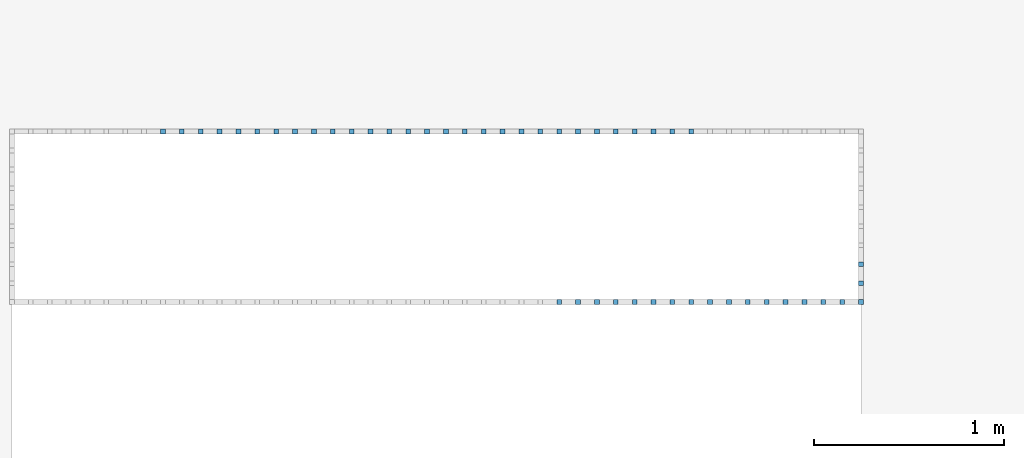
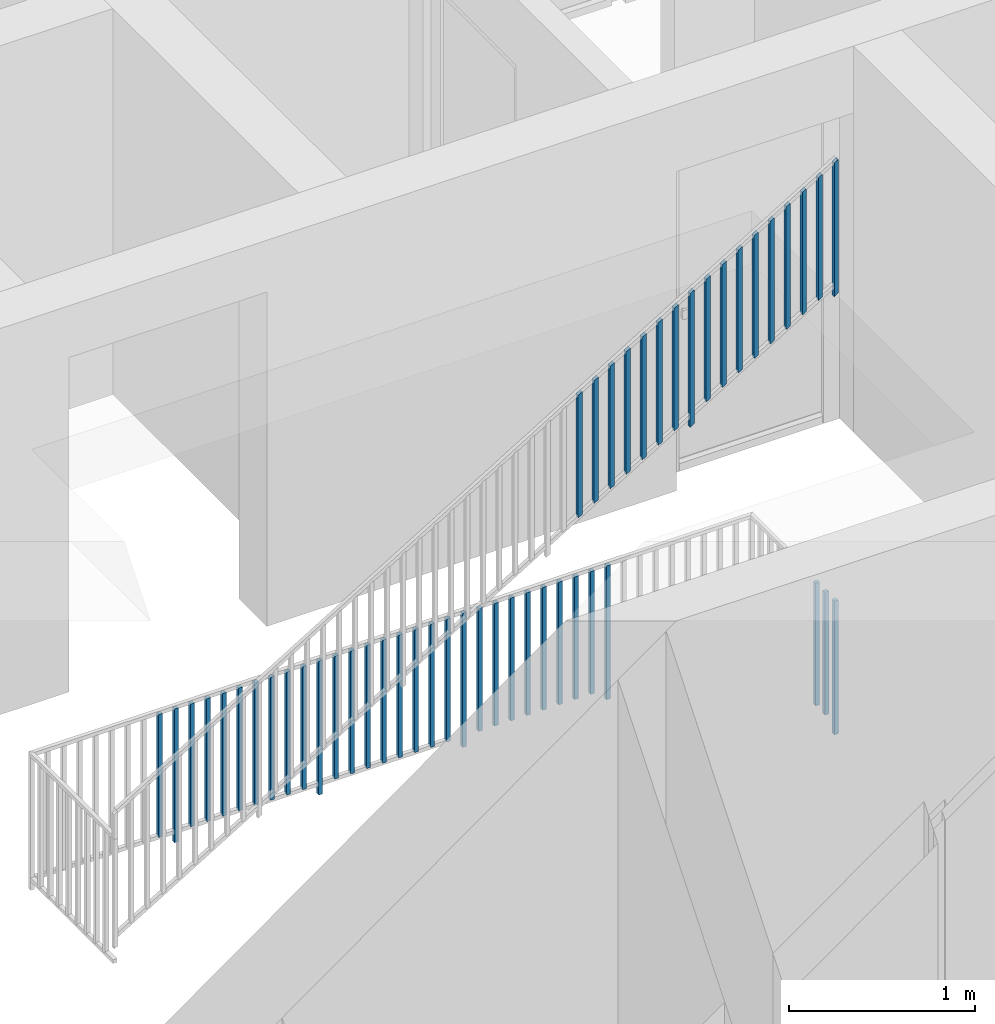
# One storey, part 40 of 54: 49 building element parts, 2 elements without a shape of their own.
"""IFC4 building model written with IfcOpenShell, lengths in metres."""

from ifc_helpers import new_model, entity, si_unit, converted_unit, derived_unit, direction, frame, origin_with_axes, place, context, subcontext, project, spatial, polygons, material, type_object, element, aggregate, save


model = new_model("IFC4")

# Units and contexts
model_context = context("Model", 3, precision=1e-05, world=origin_with_axes(), true_north=direction((0.0, 1.0)))
body_context = subcontext(model_context, "Body", "Model", "MODEL_VIEW")
ifc_project = project(units=[si_unit("LENGTHUNIT", "METRE"), si_unit("AREAUNIT", "SQUARE_METRE"), si_unit("VOLUMEUNIT", "CUBIC_METRE"), converted_unit("PLANEANGLEUNIT", "DEGREE", entity("IfcPlaneAngleMeasure", 0.0174532925199), si_unit("PLANEANGLEUNIT", "RADIAN"), dimensions=[0, 0, 0, 0, 0, 0, 0]), converted_unit("TIMEUNIT", "Year", entity("IfcTimeMeasure", 31556926.0), si_unit("TIMEUNIT", "SECOND"), dimensions=[0, 0, 1, 0, 0, 0, 0]), si_unit("MASSUNIT", "GRAM", prefix="KILO"), si_unit("THERMODYNAMICTEMPERATUREUNIT", "DEGREE_CELSIUS"), si_unit("LUMINOUSINTENSITYUNIT", "LUMEN"), si_unit("ENERGYUNIT", "JOULE", prefix="MEGA"), derived_unit("THERMALCONDUCTANCEUNIT", [(si_unit("POWERUNIT", "WATT"), 1), (si_unit("LENGTHUNIT", "METRE"), -1), (si_unit("THERMODYNAMICTEMPERATUREUNIT", "KELVIN"), -1)]), derived_unit("SPECIFICHEATCAPACITYUNIT", [(si_unit("ENERGYUNIT", "JOULE"), 1), (si_unit("MASSUNIT", "GRAM", prefix="KILO"), -1), (si_unit("THERMODYNAMICTEMPERATUREUNIT", "KELVIN"), -1)]), derived_unit("MASSDENSITYUNIT", [(si_unit("MASSUNIT", "GRAM", prefix="KILO"), 1), (si_unit("VOLUMEUNIT", "CUBIC_METRE"), -1)])], contexts=[model_context])

# Site, building, storey, space
site_placement = place(None, origin_with_axes())
site = spatial("IfcSite", under=ifc_project, at=site_placement, CompositionType="ELEMENT")
building_placement = place(site_placement, origin_with_axes())
building = spatial("IfcBuilding", under=site, at=building_placement, CompositionType="ELEMENT")
storey_placement = place(building_placement, frame((0.0, 0.0, 6.29), z_axis=(0.0, 0.0, 1.0), x_axis=(1.0, 0.0, 0.0)))
storey = spatial("IfcBuildingStorey", under=building, at=storey_placement, Name="2. Geschoss", CompositionType="ELEMENT", Elevation=6.29)
space_placement = place(storey_placement, frame((-3.4421993804, -2.52881223104, 0.0), z_axis=(0.0, 0.0, 1.0), x_axis=(1.0, 0.0, 0.0)))
space = spatial("IfcSpace", under=storey, at=space_placement, CompositionType="ELEMENT", PredefinedType="INTERNAL")

# Railing, building element parts
railing_type = type_object("IfcRailingType", PredefinedType="NOTDEFINED")
railing_1_placement = place(space_placement, frame((0.0, 1.5, 0.0), z_axis=(0.0, 0.0, 1.0), x_axis=(1.0, 0.0, 0.0)))
railing_1 = element("IfcRailing", 1, at=railing_1_placement, inside=space, type_object=railing_type, PredefinedType="NOTDEFINED")
ifc_material = material()
building_element_part_1_placement = place(railing_1_placement, origin_with_axes())
building_element_part_1 = element("IfcBuildingElementPart", 2, at=building_element_part_1_placement, material=ifc_material, PredefinedType="NOTDEFINED", context=body_context, shape_type="Tessellation", body=[
    polygons([(4.4675, -0.0125, 0.0), (4.4925, -0.0125, 0.0), (4.4925, -0.0125, 0.88), (4.4675, -0.0125, 0.88), (4.4675, 0.0125, 0.0), (4.4925, 0.0125, 0.0), (4.4925, 0.0125, 0.88), (4.4675, 0.0125, 0.88)], [[[1, 2, 3, 4]], [[1, 5, 6, 2]], [[2, 6, 7, 3]], [[4, 3, 7, 8]], [[5, 1, 4, 8]], [[6, 5, 8, 7]]], closed=True),
])
building_element_part_2_placement = place(railing_1_placement, origin_with_axes())
building_element_part_2 = element("IfcBuildingElementPart", 3, at=building_element_part_2_placement, material=ifc_material, PredefinedType="NOTDEFINED", context=body_context, shape_type="Tessellation", body=[
    polygons([(0.808944444444, 0.8875, 0.07), (0.808944444444, 0.9125, 0.07), (0.808944444444, 0.9125, 0.8775), (0.808944444444, 0.8875, 0.8775), (0.783944444444, 0.8875, 0.07), (0.783944444444, 0.9125, 0.07), (0.783944444444, 0.9125, 0.8775), (0.783944444444, 0.8875, 0.8775)], [[[1, 2, 3, 4]], [[1, 5, 6, 2]], [[2, 6, 7, 3]], [[4, 3, 7, 8]], [[5, 1, 4, 8]], [[6, 5, 8, 7]]], closed=True),
])
building_element_part_3_placement = place(railing_1_placement, origin_with_axes())
building_element_part_3 = element("IfcBuildingElementPart", 4, at=building_element_part_3_placement, material=ifc_material, PredefinedType="NOTDEFINED", context=body_context, shape_type="Tessellation", body=[
    polygons([(0.9085, 0.8875, 0.0), (0.9085, 0.9125, 0.0), (0.9085, 0.9125, 0.88), (0.9085, 0.8875, 0.88), (0.8835, 0.8875, 0.0), (0.8835, 0.9125, 0.0), (0.8835, 0.9125, 0.88), (0.8835, 0.8875, 0.88)], [[[1, 2, 3, 4]], [[1, 5, 6, 2]], [[2, 6, 7, 3]], [[4, 3, 7, 8]], [[5, 1, 4, 8]], [[6, 5, 8, 7]]], closed=True),
])
building_element_part_4_placement = place(railing_1_placement, origin_with_axes())
building_element_part_4 = element("IfcBuildingElementPart", 5, at=building_element_part_4_placement, material=ifc_material, PredefinedType="NOTDEFINED", context=body_context, shape_type="Tessellation", body=[
    polygons([(1.00805555556, 0.8875, 0.07), (1.00805555556, 0.9125, 0.07), (1.00805555556, 0.9125, 0.8775), (1.00805555556, 0.8875, 0.8775), (0.983055555556, 0.8875, 0.07), (0.983055555556, 0.9125, 0.07), (0.983055555556, 0.9125, 0.8775), (0.983055555556, 0.8875, 0.8775)], [[[1, 2, 3, 4]], [[1, 5, 6, 2]], [[2, 6, 7, 3]], [[4, 3, 7, 8]], [[5, 1, 4, 8]], [[6, 5, 8, 7]]], closed=True),
])
building_element_part_5_placement = place(railing_1_placement, origin_with_axes())
building_element_part_5 = element("IfcBuildingElementPart", 6, at=building_element_part_5_placement, material=ifc_material, PredefinedType="NOTDEFINED", context=body_context, shape_type="Tessellation", body=[
    polygons([(1.10761111111, 0.8875, 0.07), (1.10761111111, 0.9125, 0.07), (1.10761111111, 0.9125, 0.8775), (1.10761111111, 0.8875, 0.8775), (1.08261111111, 0.8875, 0.07), (1.08261111111, 0.9125, 0.07), (1.08261111111, 0.9125, 0.8775), (1.08261111111, 0.8875, 0.8775)], [[[1, 2, 3, 4]], [[1, 5, 6, 2]], [[2, 6, 7, 3]], [[4, 3, 7, 8]], [[5, 1, 4, 8]], [[6, 5, 8, 7]]], closed=True),
])
building_element_part_6_placement = place(railing_1_placement, origin_with_axes())
building_element_part_6 = element("IfcBuildingElementPart", 7, at=building_element_part_6_placement, material=ifc_material, PredefinedType="NOTDEFINED", context=body_context, shape_type="Tessellation", body=[
    polygons([(1.20716666667, 0.8875, 0.07), (1.20716666667, 0.9125, 0.07), (1.20716666667, 0.9125, 0.8775), (1.20716666667, 0.8875, 0.8775), (1.18216666667, 0.8875, 0.07), (1.18216666667, 0.9125, 0.07), (1.18216666667, 0.9125, 0.8775), (1.18216666667, 0.8875, 0.8775)], [[[1, 2, 3, 4]], [[1, 5, 6, 2]], [[2, 6, 7, 3]], [[4, 3, 7, 8]], [[5, 1, 4, 8]], [[6, 5, 8, 7]]], closed=True),
])
building_element_part_7_placement = place(railing_1_placement, origin_with_axes())
building_element_part_7 = element("IfcBuildingElementPart", 8, at=building_element_part_7_placement, material=ifc_material, PredefinedType="NOTDEFINED", context=body_context, shape_type="Tessellation", body=[
    polygons([(1.30672222222, 0.8875, 0.07), (1.30672222222, 0.9125, 0.07), (1.30672222222, 0.9125, 0.8775), (1.30672222222, 0.8875, 0.8775), (1.28172222222, 0.8875, 0.07), (1.28172222222, 0.9125, 0.07), (1.28172222222, 0.9125, 0.8775), (1.28172222222, 0.8875, 0.8775)], [[[1, 2, 3, 4]], [[1, 5, 6, 2]], [[2, 6, 7, 3]], [[4, 3, 7, 8]], [[5, 1, 4, 8]], [[6, 5, 8, 7]]], closed=True),
])
building_element_part_8_placement = place(railing_1_placement, origin_with_axes())
building_element_part_8 = element("IfcBuildingElementPart", 9, at=building_element_part_8_placement, material=ifc_material, PredefinedType="NOTDEFINED", context=body_context, shape_type="Tessellation", body=[
    polygons([(1.40627777778, 0.8875, 0.07), (1.40627777778, 0.9125, 0.07), (1.40627777778, 0.9125, 0.8775), (1.40627777778, 0.8875, 0.8775), (1.38127777778, 0.8875, 0.07), (1.38127777778, 0.9125, 0.07), (1.38127777778, 0.9125, 0.8775), (1.38127777778, 0.8875, 0.8775)], [[[1, 2, 3, 4]], [[1, 5, 6, 2]], [[2, 6, 7, 3]], [[4, 3, 7, 8]], [[5, 1, 4, 8]], [[6, 5, 8, 7]]], closed=True),
])
building_element_part_9_placement = place(railing_1_placement, origin_with_axes())
building_element_part_9 = element("IfcBuildingElementPart", 10, at=building_element_part_9_placement, material=ifc_material, PredefinedType="NOTDEFINED", context=body_context, shape_type="Tessellation", body=[
    polygons([(1.50583333333, 0.8875, 0.07), (1.50583333333, 0.9125, 0.07), (1.50583333333, 0.9125, 0.8775), (1.50583333333, 0.8875, 0.8775), (1.48083333333, 0.8875, 0.07), (1.48083333333, 0.9125, 0.07), (1.48083333333, 0.9125, 0.8775), (1.48083333333, 0.8875, 0.8775)], [[[1, 2, 3, 4]], [[1, 5, 6, 2]], [[2, 6, 7, 3]], [[4, 3, 7, 8]], [[5, 1, 4, 8]], [[6, 5, 8, 7]]], closed=True),
])
building_element_part_10_placement = place(railing_1_placement, origin_with_axes())
building_element_part_10 = element("IfcBuildingElementPart", 11, at=building_element_part_10_placement, material=ifc_material, PredefinedType="NOTDEFINED", context=body_context, shape_type="Tessellation", body=[
    polygons([(1.60538888889, 0.8875, 0.07), (1.60538888889, 0.9125, 0.07), (1.60538888889, 0.9125, 0.8775), (1.60538888889, 0.8875, 0.8775), (1.58038888889, 0.8875, 0.07), (1.58038888889, 0.9125, 0.07), (1.58038888889, 0.9125, 0.8775), (1.58038888889, 0.8875, 0.8775)], [[[1, 2, 3, 4]], [[1, 5, 6, 2]], [[2, 6, 7, 3]], [[4, 3, 7, 8]], [[5, 1, 4, 8]], [[6, 5, 8, 7]]], closed=True),
])
building_element_part_11_placement = place(railing_1_placement, origin_with_axes())
building_element_part_11 = element("IfcBuildingElementPart", 12, at=building_element_part_11_placement, material=ifc_material, PredefinedType="NOTDEFINED", context=body_context, shape_type="Tessellation", body=[
    polygons([(1.70494444444, 0.8875, 0.07), (1.70494444444, 0.9125, 0.07), (1.70494444444, 0.9125, 0.8775), (1.70494444444, 0.8875, 0.8775), (1.67994444444, 0.8875, 0.07), (1.67994444444, 0.9125, 0.07), (1.67994444444, 0.9125, 0.8775), (1.67994444444, 0.8875, 0.8775)], [[[1, 2, 3, 4]], [[1, 5, 6, 2]], [[2, 6, 7, 3]], [[4, 3, 7, 8]], [[5, 1, 4, 8]], [[6, 5, 8, 7]]], closed=True),
])
building_element_part_12_placement = place(railing_1_placement, origin_with_axes())
building_element_part_12 = element("IfcBuildingElementPart", 13, at=building_element_part_12_placement, material=ifc_material, PredefinedType="NOTDEFINED", context=body_context, shape_type="Tessellation", body=[
    polygons([(1.8045, 0.8875, 0.0), (1.8045, 0.9125, 0.0), (1.8045, 0.9125, 0.88), (1.8045, 0.8875, 0.88), (1.7795, 0.8875, 0.0), (1.7795, 0.9125, 0.0), (1.7795, 0.9125, 0.88), (1.7795, 0.8875, 0.88)], [[[1, 2, 3, 4]], [[1, 5, 6, 2]], [[2, 6, 7, 3]], [[4, 3, 7, 8]], [[5, 1, 4, 8]], [[6, 5, 8, 7]]], closed=True),
])
building_element_part_13_placement = place(railing_1_placement, origin_with_axes())
building_element_part_13 = element("IfcBuildingElementPart", 14, at=building_element_part_13_placement, material=ifc_material, PredefinedType="NOTDEFINED", context=body_context, shape_type="Tessellation", body=[
    polygons([(1.90405555556, 0.8875, 0.07), (1.90405555556, 0.9125, 0.07), (1.90405555556, 0.9125, 0.8775), (1.90405555556, 0.8875, 0.8775), (1.87905555556, 0.8875, 0.07), (1.87905555556, 0.9125, 0.07), (1.87905555556, 0.9125, 0.8775), (1.87905555556, 0.8875, 0.8775)], [[[1, 2, 3, 4]], [[1, 5, 6, 2]], [[2, 6, 7, 3]], [[4, 3, 7, 8]], [[5, 1, 4, 8]], [[6, 5, 8, 7]]], closed=True),
])
building_element_part_14_placement = place(railing_1_placement, origin_with_axes())
building_element_part_14 = element("IfcBuildingElementPart", 15, at=building_element_part_14_placement, material=ifc_material, PredefinedType="NOTDEFINED", context=body_context, shape_type="Tessellation", body=[
    polygons([(2.00361111111, 0.8875, 0.07), (2.00361111111, 0.9125, 0.07), (2.00361111111, 0.9125, 0.8775), (2.00361111111, 0.8875, 0.8775), (1.97861111111, 0.8875, 0.07), (1.97861111111, 0.9125, 0.07), (1.97861111111, 0.9125, 0.8775), (1.97861111111, 0.8875, 0.8775)], [[[1, 2, 3, 4]], [[1, 5, 6, 2]], [[2, 6, 7, 3]], [[4, 3, 7, 8]], [[5, 1, 4, 8]], [[6, 5, 8, 7]]], closed=True),
])
building_element_part_15_placement = place(railing_1_placement, origin_with_axes())
building_element_part_15 = element("IfcBuildingElementPart", 16, at=building_element_part_15_placement, material=ifc_material, PredefinedType="NOTDEFINED", context=body_context, shape_type="Tessellation", body=[
    polygons([(2.10316666667, 0.8875, 0.07), (2.10316666667, 0.9125, 0.07), (2.10316666667, 0.9125, 0.8775), (2.10316666667, 0.8875, 0.8775), (2.07816666667, 0.8875, 0.07), (2.07816666667, 0.9125, 0.07), (2.07816666667, 0.9125, 0.8775), (2.07816666667, 0.8875, 0.8775)], [[[1, 2, 3, 4]], [[1, 5, 6, 2]], [[2, 6, 7, 3]], [[4, 3, 7, 8]], [[5, 1, 4, 8]], [[6, 5, 8, 7]]], closed=True),
])
building_element_part_16_placement = place(railing_1_placement, origin_with_axes())
building_element_part_16 = element("IfcBuildingElementPart", 17, at=building_element_part_16_placement, material=ifc_material, PredefinedType="NOTDEFINED", context=body_context, shape_type="Tessellation", body=[
    polygons([(2.20272222222, 0.8875, 0.07), (2.20272222222, 0.9125, 0.07), (2.20272222222, 0.9125, 0.8775), (2.20272222222, 0.8875, 0.8775), (2.17772222222, 0.8875, 0.07), (2.17772222222, 0.9125, 0.07), (2.17772222222, 0.9125, 0.8775), (2.17772222222, 0.8875, 0.8775)], [[[1, 2, 3, 4]], [[1, 5, 6, 2]], [[2, 6, 7, 3]], [[4, 3, 7, 8]], [[5, 1, 4, 8]], [[6, 5, 8, 7]]], closed=True),
])
building_element_part_17_placement = place(railing_1_placement, origin_with_axes())
building_element_part_17 = element("IfcBuildingElementPart", 18, at=building_element_part_17_placement, material=ifc_material, PredefinedType="NOTDEFINED", context=body_context, shape_type="Tessellation", body=[
    polygons([(2.30227777778, 0.8875, 0.07), (2.30227777778, 0.9125, 0.07), (2.30227777778, 0.9125, 0.8775), (2.30227777778, 0.8875, 0.8775), (2.27727777778, 0.8875, 0.07), (2.27727777778, 0.9125, 0.07), (2.27727777778, 0.9125, 0.8775), (2.27727777778, 0.8875, 0.8775)], [[[1, 2, 3, 4]], [[1, 5, 6, 2]], [[2, 6, 7, 3]], [[4, 3, 7, 8]], [[5, 1, 4, 8]], [[6, 5, 8, 7]]], closed=True),
])
building_element_part_18_placement = place(railing_1_placement, origin_with_axes())
building_element_part_18 = element("IfcBuildingElementPart", 19, at=building_element_part_18_placement, material=ifc_material, PredefinedType="NOTDEFINED", context=body_context, shape_type="Tessellation", body=[
    polygons([(2.40183333333, 0.8875, 0.07), (2.40183333333, 0.9125, 0.07), (2.40183333333, 0.9125, 0.8775), (2.40183333333, 0.8875, 0.8775), (2.37683333333, 0.8875, 0.07), (2.37683333333, 0.9125, 0.07), (2.37683333333, 0.9125, 0.8775), (2.37683333333, 0.8875, 0.8775)], [[[1, 2, 3, 4]], [[1, 5, 6, 2]], [[2, 6, 7, 3]], [[4, 3, 7, 8]], [[5, 1, 4, 8]], [[6, 5, 8, 7]]], closed=True),
])
building_element_part_19_placement = place(railing_1_placement, origin_with_axes())
building_element_part_19 = element("IfcBuildingElementPart", 20, at=building_element_part_19_placement, material=ifc_material, PredefinedType="NOTDEFINED", context=body_context, shape_type="Tessellation", body=[
    polygons([(2.50138888889, 0.8875, 0.07), (2.50138888889, 0.9125, 0.07), (2.50138888889, 0.9125, 0.8775), (2.50138888889, 0.8875, 0.8775), (2.47638888889, 0.8875, 0.07), (2.47638888889, 0.9125, 0.07), (2.47638888889, 0.9125, 0.8775), (2.47638888889, 0.8875, 0.8775)], [[[1, 2, 3, 4]], [[1, 5, 6, 2]], [[2, 6, 7, 3]], [[4, 3, 7, 8]], [[5, 1, 4, 8]], [[6, 5, 8, 7]]], closed=True),
])
building_element_part_20_placement = place(railing_1_placement, origin_with_axes())
building_element_part_20 = element("IfcBuildingElementPart", 21, at=building_element_part_20_placement, material=ifc_material, PredefinedType="NOTDEFINED", context=body_context, shape_type="Tessellation", body=[
    polygons([(2.60094444444, 0.8875, 0.07), (2.60094444444, 0.9125, 0.07), (2.60094444444, 0.9125, 0.8775), (2.60094444444, 0.8875, 0.8775), (2.57594444444, 0.8875, 0.07), (2.57594444444, 0.9125, 0.07), (2.57594444444, 0.9125, 0.8775), (2.57594444444, 0.8875, 0.8775)], [[[1, 2, 3, 4]], [[1, 5, 6, 2]], [[2, 6, 7, 3]], [[4, 3, 7, 8]], [[5, 1, 4, 8]], [[6, 5, 8, 7]]], closed=True),
])
building_element_part_21_placement = place(railing_1_placement, origin_with_axes())
building_element_part_21 = element("IfcBuildingElementPart", 22, at=building_element_part_21_placement, material=ifc_material, PredefinedType="NOTDEFINED", context=body_context, shape_type="Tessellation", body=[
    polygons([(2.7005, 0.8875, 0.0), (2.7005, 0.9125, 0.0), (2.7005, 0.9125, 0.88), (2.7005, 0.8875, 0.88), (2.6755, 0.8875, 0.0), (2.6755, 0.9125, 0.0), (2.6755, 0.9125, 0.88), (2.6755, 0.8875, 0.88)], [[[1, 2, 3, 4]], [[1, 5, 6, 2]], [[2, 6, 7, 3]], [[4, 3, 7, 8]], [[5, 1, 4, 8]], [[6, 5, 8, 7]]], closed=True),
])
building_element_part_22_placement = place(railing_1_placement, origin_with_axes())
building_element_part_22 = element("IfcBuildingElementPart", 23, at=building_element_part_22_placement, material=ifc_material, PredefinedType="NOTDEFINED", context=body_context, shape_type="Tessellation", body=[
    polygons([(2.80005555556, 0.8875, 0.07), (2.80005555556, 0.9125, 0.07), (2.80005555556, 0.9125, 0.8775), (2.80005555556, 0.8875, 0.8775), (2.77505555556, 0.8875, 0.07), (2.77505555556, 0.9125, 0.07), (2.77505555556, 0.9125, 0.8775), (2.77505555556, 0.8875, 0.8775)], [[[1, 2, 3, 4]], [[1, 5, 6, 2]], [[2, 6, 7, 3]], [[4, 3, 7, 8]], [[5, 1, 4, 8]], [[6, 5, 8, 7]]], closed=True),
])
building_element_part_23_placement = place(railing_1_placement, origin_with_axes())
building_element_part_23 = element("IfcBuildingElementPart", 24, at=building_element_part_23_placement, material=ifc_material, PredefinedType="NOTDEFINED", context=body_context, shape_type="Tessellation", body=[
    polygons([(2.89961111111, 0.8875, 0.07), (2.89961111111, 0.9125, 0.07), (2.89961111111, 0.9125, 0.8775), (2.89961111111, 0.8875, 0.8775), (2.87461111111, 0.8875, 0.07), (2.87461111111, 0.9125, 0.07), (2.87461111111, 0.9125, 0.8775), (2.87461111111, 0.8875, 0.8775)], [[[1, 2, 3, 4]], [[1, 5, 6, 2]], [[2, 6, 7, 3]], [[4, 3, 7, 8]], [[5, 1, 4, 8]], [[6, 5, 8, 7]]], closed=True),
])
building_element_part_24_placement = place(railing_1_placement, origin_with_axes())
building_element_part_24 = element("IfcBuildingElementPart", 25, at=building_element_part_24_placement, material=ifc_material, PredefinedType="NOTDEFINED", context=body_context, shape_type="Tessellation", body=[
    polygons([(2.99916666667, 0.8875, 0.07), (2.99916666667, 0.9125, 0.07), (2.99916666667, 0.9125, 0.8775), (2.99916666667, 0.8875, 0.8775), (2.97416666667, 0.8875, 0.07), (2.97416666667, 0.9125, 0.07), (2.97416666667, 0.9125, 0.8775), (2.97416666667, 0.8875, 0.8775)], [[[1, 2, 3, 4]], [[1, 5, 6, 2]], [[2, 6, 7, 3]], [[4, 3, 7, 8]], [[5, 1, 4, 8]], [[6, 5, 8, 7]]], closed=True),
])
building_element_part_25_placement = place(railing_1_placement, origin_with_axes())
building_element_part_25 = element("IfcBuildingElementPart", 26, at=building_element_part_25_placement, material=ifc_material, PredefinedType="NOTDEFINED", context=body_context, shape_type="Tessellation", body=[
    polygons([(3.09872222222, 0.8875, 0.07), (3.09872222222, 0.9125, 0.07), (3.09872222222, 0.9125, 0.8775), (3.09872222222, 0.8875, 0.8775), (3.07372222222, 0.8875, 0.07), (3.07372222222, 0.9125, 0.07), (3.07372222222, 0.9125, 0.8775), (3.07372222222, 0.8875, 0.8775)], [[[1, 2, 3, 4]], [[1, 5, 6, 2]], [[2, 6, 7, 3]], [[4, 3, 7, 8]], [[5, 1, 4, 8]], [[6, 5, 8, 7]]], closed=True),
])
building_element_part_26_placement = place(railing_1_placement, origin_with_axes())
building_element_part_26 = element("IfcBuildingElementPart", 27, at=building_element_part_26_placement, material=ifc_material, PredefinedType="NOTDEFINED", context=body_context, shape_type="Tessellation", body=[
    polygons([(3.19827777778, 0.8875, 0.07), (3.19827777778, 0.9125, 0.07), (3.19827777778, 0.9125, 0.8775), (3.19827777778, 0.8875, 0.8775), (3.17327777778, 0.8875, 0.07), (3.17327777778, 0.9125, 0.07), (3.17327777778, 0.9125, 0.8775), (3.17327777778, 0.8875, 0.8775)], [[[1, 2, 3, 4]], [[1, 5, 6, 2]], [[2, 6, 7, 3]], [[4, 3, 7, 8]], [[5, 1, 4, 8]], [[6, 5, 8, 7]]], closed=True),
])
building_element_part_27_placement = place(railing_1_placement, origin_with_axes())
building_element_part_27 = element("IfcBuildingElementPart", 28, at=building_element_part_27_placement, material=ifc_material, PredefinedType="NOTDEFINED", context=body_context, shape_type="Tessellation", body=[
    polygons([(3.29783333333, 0.8875, 0.07), (3.29783333333, 0.9125, 0.07), (3.29783333333, 0.9125, 0.8775), (3.29783333333, 0.8875, 0.8775), (3.27283333333, 0.8875, 0.07), (3.27283333333, 0.9125, 0.07), (3.27283333333, 0.9125, 0.8775), (3.27283333333, 0.8875, 0.8775)], [[[1, 2, 3, 4]], [[1, 5, 6, 2]], [[2, 6, 7, 3]], [[4, 3, 7, 8]], [[5, 1, 4, 8]], [[6, 5, 8, 7]]], closed=True),
])
building_element_part_28_placement = place(railing_1_placement, origin_with_axes())
building_element_part_28 = element("IfcBuildingElementPart", 29, at=building_element_part_28_placement, material=ifc_material, PredefinedType="NOTDEFINED", context=body_context, shape_type="Tessellation", body=[
    polygons([(3.39738888889, 0.8875, 0.07), (3.39738888889, 0.9125, 0.07), (3.39738888889, 0.9125, 0.8775), (3.39738888889, 0.8875, 0.8775), (3.37238888889, 0.8875, 0.07), (3.37238888889, 0.9125, 0.07), (3.37238888889, 0.9125, 0.8775), (3.37238888889, 0.8875, 0.8775)], [[[1, 2, 3, 4]], [[1, 5, 6, 2]], [[2, 6, 7, 3]], [[4, 3, 7, 8]], [[5, 1, 4, 8]], [[6, 5, 8, 7]]], closed=True),
])
building_element_part_29_placement = place(railing_1_placement, origin_with_axes())
building_element_part_29 = element("IfcBuildingElementPart", 30, at=building_element_part_29_placement, material=ifc_material, PredefinedType="NOTDEFINED", context=body_context, shape_type="Tessellation", body=[
    polygons([(3.49694444444, 0.8875, 0.07), (3.49694444444, 0.9125, 0.07), (3.49694444444, 0.9125, 0.8775), (3.49694444444, 0.8875, 0.8775), (3.47194444444, 0.8875, 0.07), (3.47194444444, 0.9125, 0.07), (3.47194444444, 0.9125, 0.8775), (3.47194444444, 0.8875, 0.8775)], [[[1, 2, 3, 4]], [[1, 5, 6, 2]], [[2, 6, 7, 3]], [[4, 3, 7, 8]], [[5, 1, 4, 8]], [[6, 5, 8, 7]]], closed=True),
])
building_element_part_30_placement = place(railing_1_placement, origin_with_axes())
building_element_part_30 = element("IfcBuildingElementPart", 31, at=building_element_part_30_placement, material=ifc_material, PredefinedType="NOTDEFINED", context=body_context, shape_type="Tessellation", body=[
    polygons([(3.5965, 0.8875, 0.0), (3.5965, 0.9125, 0.0), (3.5965, 0.9125, 0.88), (3.5965, 0.8875, 0.88), (3.5715, 0.8875, 0.0), (3.5715, 0.9125, 0.0), (3.5715, 0.9125, 0.88), (3.5715, 0.8875, 0.88)], [[[1, 2, 3, 4]], [[1, 5, 6, 2]], [[2, 6, 7, 3]], [[4, 3, 7, 8]], [[5, 1, 4, 8]], [[6, 5, 8, 7]]], closed=True),
])
building_element_part_31_placement = place(railing_1_placement, origin_with_axes())
building_element_part_31 = element("IfcBuildingElementPart", 32, at=building_element_part_31_placement, material=ifc_material, PredefinedType="NOTDEFINED", context=body_context, shape_type="Tessellation", body=[
    polygons([(4.4675, 0.1875, 0.07), (4.4925, 0.1875, 0.07), (4.4925, 0.1875, 0.8775), (4.4675, 0.1875, 0.8775), (4.4675, 0.2125, 0.07), (4.4925, 0.2125, 0.07), (4.4925, 0.2125, 0.8775), (4.4675, 0.2125, 0.8775)], [[[1, 2, 3, 4]], [[1, 5, 6, 2]], [[2, 6, 7, 3]], [[4, 3, 7, 8]], [[5, 1, 4, 8]], [[6, 5, 8, 7]]], closed=True),
])
building_element_part_32_placement = place(railing_1_placement, origin_with_axes())
building_element_part_32 = element("IfcBuildingElementPart", 33, at=building_element_part_32_placement, material=ifc_material, PredefinedType="NOTDEFINED", context=body_context, shape_type="Tessellation", body=[
    polygons([(4.4675, 0.0875, 0.07), (4.4925, 0.0875, 0.07), (4.4925, 0.0875, 0.8775), (4.4675, 0.0875, 0.8775), (4.4675, 0.1125, 0.07), (4.4925, 0.1125, 0.07), (4.4925, 0.1125, 0.8775), (4.4675, 0.1125, 0.8775)], [[[1, 2, 3, 4]], [[1, 5, 6, 2]], [[2, 6, 7, 3]], [[4, 3, 7, 8]], [[5, 1, 4, 8]], [[6, 5, 8, 7]]], closed=True),
])
aggregate(railing_1, [building_element_part_1, building_element_part_2, building_element_part_3, building_element_part_4, building_element_part_5, building_element_part_6, building_element_part_7, building_element_part_8, building_element_part_9, building_element_part_10, building_element_part_11, building_element_part_12, building_element_part_13, building_element_part_14, building_element_part_15, building_element_part_16, building_element_part_17, building_element_part_18, building_element_part_19, building_element_part_20, building_element_part_21, building_element_part_22, building_element_part_23, building_element_part_24, building_element_part_25, building_element_part_26, building_element_part_27, building_element_part_28, building_element_part_29, building_element_part_30, building_element_part_31, building_element_part_32])

railing_2_placement = place(space_placement, frame((0.0, 1.5, 0.17), z_axis=(0.0, 0.0, 1.0), x_axis=(1.0, 0.0, 0.0)))
railing_2 = element("IfcRailing", 34, at=railing_2_placement, inside=space, type_object=railing_type, PredefinedType="NOTDEFINED")
building_element_part_33_placement = place(railing_2_placement, origin_with_axes())
building_element_part_33 = element("IfcBuildingElementPart", 35, at=building_element_part_33_placement, material=ifc_material, PredefinedType="NOTDEFINED", context=body_context, shape_type="Tessellation", body=[
    polygons([(4.4925, -0.0125, 2.72758928571), (4.4925, 0.0125, 2.72758928571), (4.4925, 0.0125, 3.60758928571), (4.4925, -0.0125, 3.60758928571), (4.4675, -0.0125, 2.71241071429), (4.4675, 0.0125, 2.71241071429), (4.4675, 0.0125, 3.59241071429), (4.4675, -0.0125, 3.59241071429)], [[[1, 2, 3, 4]], [[1, 5, 6, 2]], [[2, 6, 7, 3]], [[4, 3, 7, 8]], [[5, 1, 4, 8]], [[6, 5, 8, 7]]], closed=True),
])
building_element_part_34_placement = place(railing_2_placement, origin_with_axes())
building_element_part_34 = element("IfcBuildingElementPart", 36, at=building_element_part_34_placement, material=ifc_material, PredefinedType="NOTDEFINED", context=body_context, shape_type="Tessellation", body=[
    polygons([(2.89961111111, -0.0125, 1.8304781746), (2.89961111111, 0.0125, 1.8304781746), (2.89961111111, 0.0125, 2.6379781746), (2.89961111111, -0.0125, 2.6379781746), (2.87461111111, -0.0125, 1.81529960317), (2.87461111111, 0.0125, 1.81529960317), (2.87461111111, 0.0125, 2.62279960317), (2.87461111111, -0.0125, 2.62279960317)], [[[1, 2, 3, 4]], [[1, 5, 6, 2]], [[2, 6, 7, 3]], [[4, 3, 7, 8]], [[5, 1, 4, 8]], [[6, 5, 8, 7]]], closed=True),
])
building_element_part_35_placement = place(railing_2_placement, origin_with_axes())
building_element_part_35 = element("IfcBuildingElementPart", 37, at=building_element_part_35_placement, material=ifc_material, PredefinedType="NOTDEFINED", context=body_context, shape_type="Tessellation", body=[
    polygons([(2.99916666667, -0.0125, 1.89092261905), (2.99916666667, 0.0125, 1.89092261905), (2.99916666667, 0.0125, 2.69842261905), (2.99916666667, -0.0125, 2.69842261905), (2.97416666667, -0.0125, 1.87574404762), (2.97416666667, 0.0125, 1.87574404762), (2.97416666667, 0.0125, 2.68324404762), (2.97416666667, -0.0125, 2.68324404762)], [[[1, 2, 3, 4]], [[1, 5, 6, 2]], [[2, 6, 7, 3]], [[4, 3, 7, 8]], [[5, 1, 4, 8]], [[6, 5, 8, 7]]], closed=True),
])
building_element_part_36_placement = place(railing_2_placement, origin_with_axes())
building_element_part_36 = element("IfcBuildingElementPart", 38, at=building_element_part_36_placement, material=ifc_material, PredefinedType="NOTDEFINED", context=body_context, shape_type="Tessellation", body=[
    polygons([(3.09872222222, -0.0125, 1.95136706349), (3.09872222222, 0.0125, 1.95136706349), (3.09872222222, 0.0125, 2.75886706349), (3.09872222222, -0.0125, 2.75886706349), (3.07372222222, -0.0125, 1.93618849206), (3.07372222222, 0.0125, 1.93618849206), (3.07372222222, 0.0125, 2.74368849206), (3.07372222222, -0.0125, 2.74368849206)], [[[1, 2, 3, 4]], [[1, 5, 6, 2]], [[2, 6, 7, 3]], [[4, 3, 7, 8]], [[5, 1, 4, 8]], [[6, 5, 8, 7]]], closed=True),
])
building_element_part_37_placement = place(railing_2_placement, origin_with_axes())
building_element_part_37 = element("IfcBuildingElementPart", 39, at=building_element_part_37_placement, material=ifc_material, PredefinedType="NOTDEFINED", context=body_context, shape_type="Tessellation", body=[
    polygons([(3.19827777778, -0.0125, 2.01181150794), (3.19827777778, 0.0125, 2.01181150794), (3.19827777778, 0.0125, 2.81931150794), (3.19827777778, -0.0125, 2.81931150794), (3.17327777778, -0.0125, 1.99663293651), (3.17327777778, 0.0125, 1.99663293651), (3.17327777778, 0.0125, 2.80413293651), (3.17327777778, -0.0125, 2.80413293651)], [[[1, 2, 3, 4]], [[1, 5, 6, 2]], [[2, 6, 7, 3]], [[4, 3, 7, 8]], [[5, 1, 4, 8]], [[6, 5, 8, 7]]], closed=True),
])
building_element_part_38_placement = place(railing_2_placement, origin_with_axes())
building_element_part_38 = element("IfcBuildingElementPart", 40, at=building_element_part_38_placement, material=ifc_material, PredefinedType="NOTDEFINED", context=body_context, shape_type="Tessellation", body=[
    polygons([(3.29783333333, -0.0125, 2.07225595238), (3.29783333333, 0.0125, 2.07225595238), (3.29783333333, 0.0125, 2.87975595238), (3.29783333333, -0.0125, 2.87975595238), (3.27283333333, -0.0125, 2.05707738095), (3.27283333333, 0.0125, 2.05707738095), (3.27283333333, 0.0125, 2.86457738095), (3.27283333333, -0.0125, 2.86457738095)], [[[1, 2, 3, 4]], [[1, 5, 6, 2]], [[2, 6, 7, 3]], [[4, 3, 7, 8]], [[5, 1, 4, 8]], [[6, 5, 8, 7]]], closed=True),
])
building_element_part_39_placement = place(railing_2_placement, origin_with_axes())
building_element_part_39 = element("IfcBuildingElementPart", 41, at=building_element_part_39_placement, material=ifc_material, PredefinedType="NOTDEFINED", context=body_context, shape_type="Tessellation", body=[
    polygons([(3.39738888889, -0.0125, 2.13270039683), (3.39738888889, 0.0125, 2.13270039683), (3.39738888889, 0.0125, 2.94020039683), (3.39738888889, -0.0125, 2.94020039683), (3.37238888889, -0.0125, 2.1175218254), (3.37238888889, 0.0125, 2.1175218254), (3.37238888889, 0.0125, 2.9250218254), (3.37238888889, -0.0125, 2.9250218254)], [[[1, 2, 3, 4]], [[1, 5, 6, 2]], [[2, 6, 7, 3]], [[4, 3, 7, 8]], [[5, 1, 4, 8]], [[6, 5, 8, 7]]], closed=True),
])
building_element_part_40_placement = place(railing_2_placement, origin_with_axes())
building_element_part_40 = element("IfcBuildingElementPart", 42, at=building_element_part_40_placement, material=ifc_material, PredefinedType="NOTDEFINED", context=body_context, shape_type="Tessellation", body=[
    polygons([(3.49694444444, -0.0125, 2.19314484127), (3.49694444444, 0.0125, 2.19314484127), (3.49694444444, 0.0125, 3.00064484127), (3.49694444444, -0.0125, 3.00064484127), (3.47194444444, -0.0125, 2.17796626984), (3.47194444444, 0.0125, 2.17796626984), (3.47194444444, 0.0125, 2.98546626984), (3.47194444444, -0.0125, 2.98546626984)], [[[1, 2, 3, 4]], [[1, 5, 6, 2]], [[2, 6, 7, 3]], [[4, 3, 7, 8]], [[5, 1, 4, 8]], [[6, 5, 8, 7]]], closed=True),
])
building_element_part_41_placement = place(railing_2_placement, origin_with_axes())
building_element_part_41 = element("IfcBuildingElementPart", 43, at=building_element_part_41_placement, material=ifc_material, PredefinedType="NOTDEFINED", context=body_context, shape_type="Tessellation", body=[
    polygons([(3.5965, -0.0125, 2.18358928571), (3.5965, 0.0125, 2.18358928571), (3.5965, 0.0125, 3.06358928571), (3.5965, -0.0125, 3.06358928571), (3.5715, -0.0125, 2.16841071429), (3.5715, 0.0125, 2.16841071429), (3.5715, 0.0125, 3.04841071429), (3.5715, -0.0125, 3.04841071429)], [[[1, 2, 3, 4]], [[1, 5, 6, 2]], [[2, 6, 7, 3]], [[4, 3, 7, 8]], [[5, 1, 4, 8]], [[6, 5, 8, 7]]], closed=True),
])
building_element_part_42_placement = place(railing_2_placement, origin_with_axes())
building_element_part_42 = element("IfcBuildingElementPart", 44, at=building_element_part_42_placement, material=ifc_material, PredefinedType="NOTDEFINED", context=body_context, shape_type="Tessellation", body=[
    polygons([(3.69605555556, -0.0125, 2.31403373016), (3.69605555556, 0.0125, 2.31403373016), (3.69605555556, 0.0125, 3.12153373016), (3.69605555556, -0.0125, 3.12153373016), (3.67105555556, -0.0125, 2.29885515873), (3.67105555556, 0.0125, 2.29885515873), (3.67105555556, 0.0125, 3.10635515873), (3.67105555556, -0.0125, 3.10635515873)], [[[1, 2, 3, 4]], [[1, 5, 6, 2]], [[2, 6, 7, 3]], [[4, 3, 7, 8]], [[5, 1, 4, 8]], [[6, 5, 8, 7]]], closed=True),
])
building_element_part_43_placement = place(railing_2_placement, origin_with_axes())
building_element_part_43 = element("IfcBuildingElementPart", 45, at=building_element_part_43_placement, material=ifc_material, PredefinedType="NOTDEFINED", context=body_context, shape_type="Tessellation", body=[
    polygons([(3.79561111111, -0.0125, 2.3744781746), (3.79561111111, 0.0125, 2.3744781746), (3.79561111111, 0.0125, 3.1819781746), (3.79561111111, -0.0125, 3.1819781746), (3.77061111111, -0.0125, 2.35929960317), (3.77061111111, 0.0125, 2.35929960317), (3.77061111111, 0.0125, 3.16679960317), (3.77061111111, -0.0125, 3.16679960317)], [[[1, 2, 3, 4]], [[1, 5, 6, 2]], [[2, 6, 7, 3]], [[4, 3, 7, 8]], [[5, 1, 4, 8]], [[6, 5, 8, 7]]], closed=True),
])
building_element_part_44_placement = place(railing_2_placement, origin_with_axes())
building_element_part_44 = element("IfcBuildingElementPart", 46, at=building_element_part_44_placement, material=ifc_material, PredefinedType="NOTDEFINED", context=body_context, shape_type="Tessellation", body=[
    polygons([(3.89516666667, -0.0125, 2.43492261905), (3.89516666667, 0.0125, 2.43492261905), (3.89516666667, 0.0125, 3.24242261905), (3.89516666667, -0.0125, 3.24242261905), (3.87016666667, -0.0125, 2.41974404762), (3.87016666667, 0.0125, 2.41974404762), (3.87016666667, 0.0125, 3.22724404762), (3.87016666667, -0.0125, 3.22724404762)], [[[1, 2, 3, 4]], [[1, 5, 6, 2]], [[2, 6, 7, 3]], [[4, 3, 7, 8]], [[5, 1, 4, 8]], [[6, 5, 8, 7]]], closed=True),
])
building_element_part_45_placement = place(railing_2_placement, origin_with_axes())
building_element_part_45 = element("IfcBuildingElementPart", 47, at=building_element_part_45_placement, material=ifc_material, PredefinedType="NOTDEFINED", context=body_context, shape_type="Tessellation", body=[
    polygons([(3.99472222222, -0.0125, 2.49536706349), (3.99472222222, 0.0125, 2.49536706349), (3.99472222222, 0.0125, 3.30286706349), (3.99472222222, -0.0125, 3.30286706349), (3.96972222222, -0.0125, 2.48018849206), (3.96972222222, 0.0125, 2.48018849206), (3.96972222222, 0.0125, 3.28768849206), (3.96972222222, -0.0125, 3.28768849206)], [[[1, 2, 3, 4]], [[1, 5, 6, 2]], [[2, 6, 7, 3]], [[4, 3, 7, 8]], [[5, 1, 4, 8]], [[6, 5, 8, 7]]], closed=True),
])
building_element_part_46_placement = place(railing_2_placement, origin_with_axes())
building_element_part_46 = element("IfcBuildingElementPart", 48, at=building_element_part_46_placement, material=ifc_material, PredefinedType="NOTDEFINED", context=body_context, shape_type="Tessellation", body=[
    polygons([(4.09427777778, -0.0125, 2.55581150794), (4.09427777778, 0.0125, 2.55581150794), (4.09427777778, 0.0125, 3.36331150794), (4.09427777778, -0.0125, 3.36331150794), (4.06927777778, -0.0125, 2.54063293651), (4.06927777778, 0.0125, 2.54063293651), (4.06927777778, 0.0125, 3.34813293651), (4.06927777778, -0.0125, 3.34813293651)], [[[1, 2, 3, 4]], [[1, 5, 6, 2]], [[2, 6, 7, 3]], [[4, 3, 7, 8]], [[5, 1, 4, 8]], [[6, 5, 8, 7]]], closed=True),
])
building_element_part_47_placement = place(railing_2_placement, origin_with_axes())
building_element_part_47 = element("IfcBuildingElementPart", 49, at=building_element_part_47_placement, material=ifc_material, PredefinedType="NOTDEFINED", context=body_context, shape_type="Tessellation", body=[
    polygons([(4.19383333333, -0.0125, 2.61625595238), (4.19383333333, 0.0125, 2.61625595238), (4.19383333333, 0.0125, 3.42375595238), (4.19383333333, -0.0125, 3.42375595238), (4.16883333333, -0.0125, 2.60107738095), (4.16883333333, 0.0125, 2.60107738095), (4.16883333333, 0.0125, 3.40857738095), (4.16883333333, -0.0125, 3.40857738095)], [[[1, 2, 3, 4]], [[1, 5, 6, 2]], [[2, 6, 7, 3]], [[4, 3, 7, 8]], [[5, 1, 4, 8]], [[6, 5, 8, 7]]], closed=True),
])
building_element_part_48_placement = place(railing_2_placement, origin_with_axes())
building_element_part_48 = element("IfcBuildingElementPart", 50, at=building_element_part_48_placement, material=ifc_material, PredefinedType="NOTDEFINED", context=body_context, shape_type="Tessellation", body=[
    polygons([(4.29338888889, -0.0125, 2.67670039683), (4.29338888889, 0.0125, 2.67670039683), (4.29338888889, 0.0125, 3.48420039683), (4.29338888889, -0.0125, 3.48420039683), (4.26838888889, -0.0125, 2.6615218254), (4.26838888889, 0.0125, 2.6615218254), (4.26838888889, 0.0125, 3.4690218254), (4.26838888889, -0.0125, 3.4690218254)], [[[1, 2, 3, 4]], [[1, 5, 6, 2]], [[2, 6, 7, 3]], [[4, 3, 7, 8]], [[5, 1, 4, 8]], [[6, 5, 8, 7]]], closed=True),
])
building_element_part_49_placement = place(railing_2_placement, origin_with_axes())
building_element_part_49 = element("IfcBuildingElementPart", 51, at=building_element_part_49_placement, material=ifc_material, PredefinedType="NOTDEFINED", context=body_context, shape_type="Tessellation", body=[
    polygons([(4.39294444444, -0.0125, 2.73714484127), (4.39294444444, 0.0125, 2.73714484127), (4.39294444444, 0.0125, 3.54464484127), (4.39294444444, -0.0125, 3.54464484127), (4.36794444444, -0.0125, 2.72196626984), (4.36794444444, 0.0125, 2.72196626984), (4.36794444444, 0.0125, 3.52946626984), (4.36794444444, -0.0125, 3.52946626984)], [[[1, 2, 3, 4]], [[1, 5, 6, 2]], [[2, 6, 7, 3]], [[4, 3, 7, 8]], [[5, 1, 4, 8]], [[6, 5, 8, 7]]], closed=True),
])
aggregate(railing_2, [building_element_part_33, building_element_part_34, building_element_part_35, building_element_part_36, building_element_part_37, building_element_part_38, building_element_part_39, building_element_part_40, building_element_part_41, building_element_part_42, building_element_part_43, building_element_part_44, building_element_part_45, building_element_part_46, building_element_part_47, building_element_part_48, building_element_part_49])

save(model, "model.ifc")
